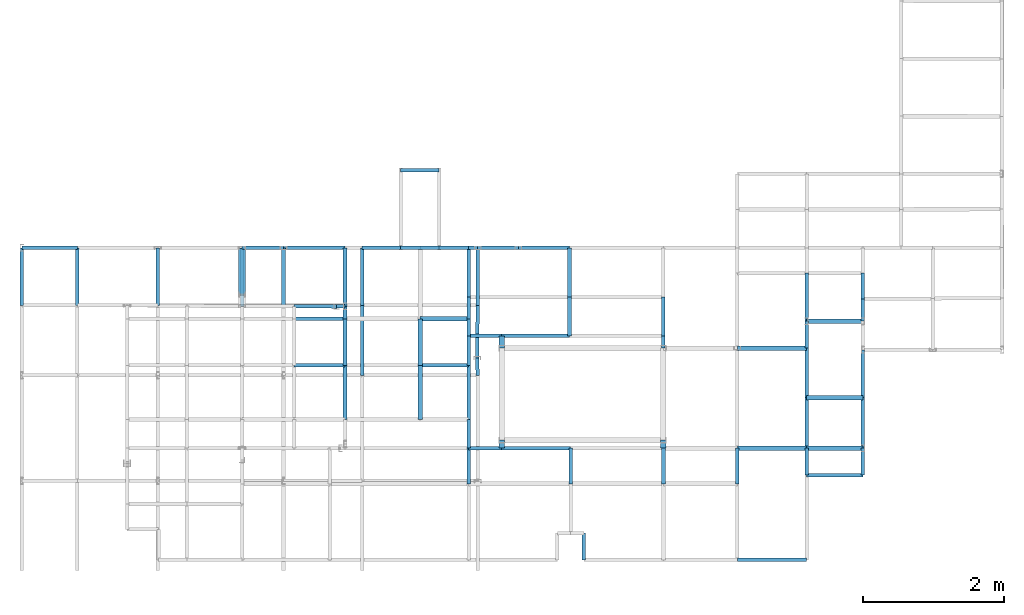
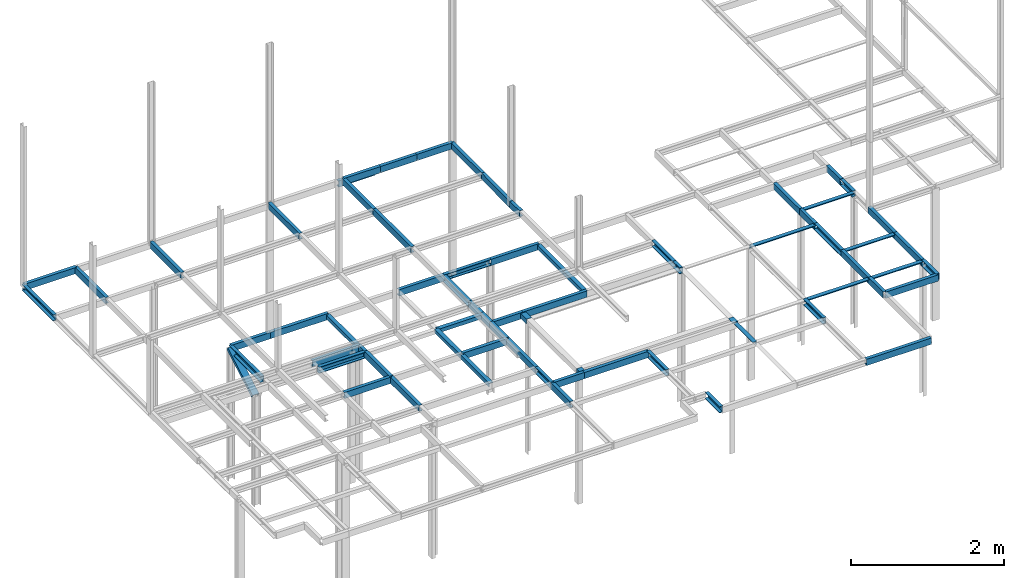
# Not in any storey, part 6 of 7: 72 beams, 1 member.
"""IFC2X3 model written with IfcOpenShell, lengths in centimetres."""

from ifc_helpers import new_model, si_unit, frame, frame_2d, origin_with_axes, origin_2d_with_axis, place, context, project, polyline, u_section, outline, extrude, material, element, save


model = new_model("IFC2X3")

# Units and contexts
model_context = context("Model", 3, precision=1e-05, world=origin_with_axes())
plan_context = context("Plan", 3, precision=1e-05, world=origin_with_axes())
ifc_project = project(units=[si_unit("LENGTHUNIT", "METRE", prefix="CENTI"), si_unit("AREAUNIT", "SQUARE_METRE", prefix="CENTI"), si_unit("VOLUMEUNIT", "CUBIC_METRE", prefix="CENTI"), si_unit("PLANEANGLEUNIT", "RADIAN"), si_unit("SOLIDANGLEUNIT", "STERADIAN"), si_unit("MASSUNIT", "GRAM"), si_unit("TIMEUNIT", "SECOND"), si_unit("THERMODYNAMICTEMPERATUREUNIT", "DEGREE_CELSIUS"), si_unit("LUMINOUSINTENSITYUNIT", "LUMEN")], contexts=[model_context, plan_context])

# Member
ifc_material = material()
member_placement = place(None, frame((-589.100036621094, 210.199996948242, 173.0), z_axis=(0.0, 0.868408043998, 0.495850248684), x_axis=(0.0, 0.495850235224, -0.868408024311)))
element("IfcMember", 1, at=member_placement, material=ifc_material, Name="UPN - de ala UPN 100", context=model_context, shape_type="SweptSolid", body=[
    extrude(u_section(Depth=10.0, FlangeWidth=5.0, WebThickness=0.6, FlangeThickness=0.85, FilletRadius=0.0, EdgeRadius=0.0, FlangeSlope=0.0, CentreOfGravityInX=0.0, at=origin_2d_with_axis()), origin_with_axes(), (0.0, 0.0, 1.0), 74.619303102534),
])

# Beams
beam_1_placement = place(None, frame((-530.299987792969, 275.0, 210.0), z_axis=(-1.0, 0.0, 0.0), x_axis=(0.0, 1.0, 0.0)))
element("IfcBeam", 2, at=beam_1_placement, material=ifc_material, Name="UPN - de ala UPN 100", context=model_context, shape_type="SweptSolid", body=[
    extrude(u_section(Depth=10.0, FlangeWidth=5.0, WebThickness=0.6, FlangeThickness=0.85, FilletRadius=0.0, EdgeRadius=0.0, FlangeSlope=0.0, CentreOfGravityInX=0.0, at=origin_2d_with_axis()), origin_with_axes(), (0.0, 0.0, 1.0), 58.800048828125),
])
beam_2_placement = place(None, frame((-589.100036621094, 192.0, 210.0), z_axis=(0.0, 1.0, 0.0), x_axis=(-1.0, 0.0, 0.0)))
element("IfcBeam", 3, at=beam_2_placement, material=ifc_material, Name="UPN - de ala UPN 100", context=model_context, shape_type="SweptSolid", body=[
    extrude(u_section(Depth=10.0, FlangeWidth=5.0, WebThickness=0.6, FlangeThickness=0.85, FilletRadius=0.0, EdgeRadius=0.0, FlangeSlope=0.0, CentreOfGravityInX=0.0, at=origin_2d_with_axis()), origin_with_axes(), (0.0, 0.0, 1.0), 83.0),
])
beam_3_placement = place(None, frame((-443.100006103516, 275.0, 210.0), z_axis=(-1.0, 0.0, 0.0), x_axis=(0.0, 1.0, 0.0)))
element("IfcBeam", 4, at=beam_3_placement, material=ifc_material, Name="UPN - de ala UPN 100", context=model_context, shape_type="SweptSolid", body=[
    extrude(u_section(Depth=10.0, FlangeWidth=5.0, WebThickness=0.6, FlangeThickness=0.85, FilletRadius=0.0, EdgeRadius=0.0, FlangeSlope=0.0, CentreOfGravityInX=0.0, at=origin_2d_with_axis()), origin_with_axes(), (0.0, 0.0, 1.0), 87.199981689453),
])
beam_4_placement = place(None, frame((-443.100006103516, 192.0, 210.0), z_axis=(0.0, 1.0, 0.0), x_axis=(-1.0, 0.0, 0.0)))
element("IfcBeam", 5, at=beam_4_placement, material=ifc_material, context=model_context, shape_type="SweptSolid", body=[
    extrude(outline(polyline([(3.0, -3.0), (3.0, 3.0), (-3.0, 3.0), (-3.0, 2.5), (2.5, 2.5), (2.5, -3.0), (3.0, -3.0)])), origin_with_axes(), (0.0, 0.0, 1.0), 83.0),
])
beam_5_placement = place(None, frame((-268.0, 275.0, 210.0), z_axis=(-1.0, 0.0, 0.0), x_axis=(0.0, 1.0, 0.0)))
element("IfcBeam", 6, at=beam_5_placement, material=ifc_material, Name="UPN - de ala UPN 100", context=model_context, shape_type="SweptSolid", body=[
    extrude(u_section(Depth=10.0, FlangeWidth=5.0, WebThickness=0.6, FlangeThickness=0.85, FilletRadius=0.0, EdgeRadius=0.0, FlangeSlope=0.0, CentreOfGravityInX=0.0, at=origin_2d_with_axis()), origin_with_axes(), (0.0, 0.0, 1.0), 68.600006103516),
])
beam_6_placement = place(None, frame((-255.0, 275.0, 210.0), z_axis=(-1.0, 0.0, 0.0), x_axis=(0.0, -1.0, 0.0)))
element("IfcBeam", 7, at=beam_6_placement, material=ifc_material, Name="UPN - de ala UPN 100", context=model_context, shape_type="SweptSolid", body=[
    extrude(u_section(Depth=10.0, FlangeWidth=5.0, WebThickness=0.6, FlangeThickness=0.85, FilletRadius=0.0, EdgeRadius=0.0, FlangeSlope=0.0, CentreOfGravityInX=0.0, at=origin_2d_with_axis()), origin_with_axes(), (0.0, 0.0, 1.0), 13.0),
])
beam_7_placement = place(None, frame((-268.0, 205.199996948242, 210.0), z_axis=(0.0, 1.0, 0.0), x_axis=(-1.0, 0.0, 0.0)))
element("IfcBeam", 8, at=beam_7_placement, material=ifc_material, Name="UPN - de ala UPN 100", context=model_context, shape_type="SweptSolid", body=[
    extrude(u_section(Depth=10.0, FlangeWidth=5.0, WebThickness=0.6, FlangeThickness=0.85, FilletRadius=0.0, EdgeRadius=0.0, FlangeSlope=0.0, CentreOfGravityInX=0.0, at=origin_2d_with_axis()), origin_with_axes(), (0.0, 0.0, 1.0), 69.800003051758),
])
beam_8_placement = place(None, frame((-197.5, 275.0, 210.0), z_axis=(-1.0, 0.0, 0.0), x_axis=(0.0, -1.0, 0.0)))
element("IfcBeam", 9, at=beam_8_placement, material=ifc_material, Name="UPN - de ala UPN 100", context=model_context, shape_type="SweptSolid", body=[
    extrude(u_section(Depth=10.0, FlangeWidth=5.0, WebThickness=0.6, FlangeThickness=0.85, FilletRadius=0.0, EdgeRadius=0.0, FlangeSlope=0.0, CentreOfGravityInX=0.0, at=origin_2d_with_axis()), origin_with_axes(), (0.0, 0.0, 1.0), 57.5),
])
beam_9_placement = place(None, frame((-124.900001525879, 275.0, 210.0), z_axis=(-1.0, 0.0, 0.0), x_axis=(0.0, 1.0, 0.0)))
element("IfcBeam", 10, at=beam_9_placement, material=ifc_material, Name="UPN - de ala UPN 100", context=model_context, shape_type="SweptSolid", body=[
    extrude(u_section(Depth=10.0, FlangeWidth=5.0, WebThickness=0.6, FlangeThickness=0.85, FilletRadius=0.0, EdgeRadius=0.0, FlangeSlope=0.0, CentreOfGravityInX=0.0, at=origin_2d_with_axis()), origin_with_axes(), (0.0, 0.0, 1.0), 72.599998474121),
])
beam_10_placement = place(None, frame((-124.900001525879, 205.199996948242, 210.0), z_axis=(0.0, 1.0, 0.0), x_axis=(-1.0, 0.0, 0.0)))
element("IfcBeam", 11, at=beam_10_placement, material=ifc_material, context=model_context, shape_type="SweptSolid", body=[
    extrude(outline(polyline([(3.0, -3.0), (3.0, 3.0), (-3.0, 3.0), (-3.0, 2.5), (2.5, 2.5), (2.5, -3.0), (3.0, -3.0)])), origin_with_axes(), (0.0, 0.0, 1.0), 69.800003051758),
])
beam_11_placement = place(None, frame((211.100006103516, 171.0, 210.0), z_axis=(0.0, 1.0, 0.0), x_axis=(1.0, 0.0, 0.0)))
element("IfcBeam", 12, at=beam_11_placement, material=ifc_material, Name="UPN - de ala UPN 100", context=model_context, shape_type="SweptSolid", body=[
    extrude(u_section(Depth=10.0, FlangeWidth=5.0, WebThickness=0.6, FlangeThickness=0.85, FilletRadius=0.0, EdgeRadius=0.0, FlangeSlope=0.0, CentreOfGravityInX=0.0, at=origin_2d_with_axis()), origin_with_axes(), (0.0, 0.0, 1.0), 68.0),
])
beam_12_placement = place(None, frame((291.100006103516, 202.699996948242, 210.0), z_axis=(0.0, 1.0, 0.0), x_axis=(1.0, 0.0, 0.0)))
element("IfcBeam", 13, at=beam_12_placement, material=ifc_material, Name="UPN - de ala UPN 100", context=model_context, shape_type="SweptSolid", body=[
    extrude(u_section(Depth=10.0, FlangeWidth=5.0, WebThickness=0.6, FlangeThickness=0.85, FilletRadius=0.0, EdgeRadius=0.0, FlangeSlope=0.0, CentreOfGravityInX=0.0, at=origin_2d_with_axis()), origin_with_axes(), (0.0, 0.0, 1.0), 36.300003051758),
])
beam_13_placement = place(None, frame((-268.0, 174.400009155273, 210.0), z_axis=(0.0, 1.0, 0.0), x_axis=(1.0, 0.0, 0.0)))
element("IfcBeam", 14, at=beam_13_placement, material=ifc_material, Name="UPN - de ala UPN 100", context=model_context, shape_type="SweptSolid", body=[
    extrude(u_section(Depth=10.0, FlangeWidth=5.0, WebThickness=0.6, FlangeThickness=0.85, FilletRadius=0.0, EdgeRadius=0.0, FlangeSlope=0.0, CentreOfGravityInX=0.0, at=origin_2d_with_axis()), origin_with_axes(), (0.0, 0.0, 1.0), 30.799987792969),
])
beam_14_placement = place(None, frame((-124.900001525879, 150.199996948242, 210.0), z_axis=(0.0, 1.0, 0.0), x_axis=(-1.0, 0.0, 0.0)))
element("IfcBeam", 15, at=beam_14_placement, material=ifc_material, context=model_context, shape_type="SweptSolid", body=[
    extrude(outline(polyline([(3.0, -3.0), (3.0, 3.0), (-3.0, 3.0), (-3.0, 2.5), (2.5, 2.5), (2.5, -3.0), (3.0, -3.0)])), origin_with_axes(), (0.0, 0.0, 1.0), 55.0),
])
beam_15_placement = place(None, frame((8.199999809265, 150.199996948242, 210.0), z_axis=(0.0, 1.0, 0.0), x_axis=(-1.0, 0.0, 0.0)))
element("IfcBeam", 16, at=beam_15_placement, material=ifc_material, Name="UPN - de ala UPN 100", context=model_context, shape_type="SweptSolid", body=[
    extrude(u_section(Depth=10.0, FlangeWidth=5.0, WebThickness=0.6, FlangeThickness=0.85, FilletRadius=0.0, EdgeRadius=0.0, FlangeSlope=0.0, CentreOfGravityInX=0.0, at=origin_2d_with_axis()), origin_with_axes(), (0.0, 0.0, 1.0), 55.0),
])
beam_16_placement = place(None, frame((291.100006103516, 171.0, 210.0), z_axis=(0.0, 1.0, 0.0), x_axis=(-1.0, 0.0, 0.0)))
element("IfcBeam", 17, at=beam_16_placement, material=ifc_material, Name="UPN - de ala UPN 100", context=model_context, shape_type="SweptSolid", body=[
    extrude(u_section(Depth=10.0, FlangeWidth=5.0, WebThickness=0.6, FlangeThickness=0.85, FilletRadius=0.0, EdgeRadius=0.0, FlangeSlope=0.0, CentreOfGravityInX=0.0, at=origin_2d_with_axis()), origin_with_axes(), (0.0, 0.0, 1.0), 31.699996948242),
])
beam_17_placement = place(None, frame((-455.200012207031, 191.800003051758, 210.0), z_axis=(0.999863429598, 0.016526407745, 0.0), x_axis=(-0.016526408494, 0.999863445759, 0.0)))
element("IfcBeam", 18, at=beam_17_placement, material=ifc_material, Name="UPN - de ala UPN 100", context=model_context, shape_type="SweptSolid", body=[
    extrude(u_section(Depth=10.0, FlangeWidth=5.0, WebThickness=0.6, FlangeThickness=0.85, FilletRadius=0.0, EdgeRadius=0.0, FlangeSlope=0.0, CentreOfGravityInX=0.0, at=frame_2d((-5.83e-09, 0.0), x_axis=(1.0, 0.0))), origin_with_axes(), (0.0, 0.0, 1.0), 12.10165883193),
])
beam_18_placement = place(None, frame((-443.100006103516, 174.400009155273, 210.0), z_axis=(0.0, 1.0, 0.0), x_axis=(1.0, 0.0, 0.0)))
element("IfcBeam", 19, at=beam_18_placement, material=ifc_material, Name="UPN - de ala UPN 100", context=model_context, shape_type="SweptSolid", body=[
    extrude(u_section(Depth=10.0, FlangeWidth=5.0, WebThickness=0.6, FlangeThickness=0.85, FilletRadius=0.0, EdgeRadius=0.0, FlangeSlope=0.0, CentreOfGravityInX=0.0, at=origin_2d_with_axis()), origin_with_axes(), (0.0, 0.0, 1.0), 17.599990844727),
])
beam_19_placement = place(None, frame((-455.200012207031, 191.800003051758, 210.0), z_axis=(-0.999998610944, 0.001666766077, 0.0), x_axis=(0.001666766126, 0.999998629093, 0.0)))
element("IfcBeam", 20, at=beam_19_placement, material=ifc_material, Name="UPN - de ala UPN 100", context=model_context, shape_type="SweptSolid", body=[
    extrude(u_section(Depth=10.0, FlangeWidth=5.0, WebThickness=0.6, FlangeThickness=0.85, FilletRadius=0.0, EdgeRadius=0.0, FlangeSlope=0.0, CentreOfGravityInX=0.0, at=frame_2d((-1.126e-09, 0.0), x_axis=(1.0, 0.0))), origin_with_axes(), (0.0, 0.0, 1.0), 60.000083343448),
])
beam_20_placement = place(None, frame((-443.100006103516, 174.400009155273, 210.0), z_axis=(-1.0, 0.0, 0.0), x_axis=(0.0, -1.0, 0.0)))
element("IfcBeam", 21, at=beam_20_placement, material=ifc_material, Name="UPN - de ala UPN 100", context=model_context, shape_type="SweptSolid", body=[
    extrude(u_section(Depth=10.0, FlangeWidth=5.0, WebThickness=0.6, FlangeThickness=0.85, FilletRadius=0.0, EdgeRadius=0.0, FlangeSlope=0.0, CentreOfGravityInX=0.0, at=origin_2d_with_axis()), origin_with_axes(), (0.0, 0.0, 1.0), 72.100006103516),
])
beam_21_placement = place(None, frame((-443.100006103516, 108.200004577637, 210.0), z_axis=(0.0, 1.0, 0.0), x_axis=(1.0, 0.0, 0.0)))
element("IfcBeam", 22, at=beam_21_placement, material=ifc_material, Name="UPN - de ala UPN 100", context=model_context, shape_type="SweptSolid", body=[
    extrude(u_section(Depth=10.0, FlangeWidth=5.0, WebThickness=0.6, FlangeThickness=0.85, FilletRadius=0.0, EdgeRadius=0.0, FlangeSlope=0.0, CentreOfGravityInX=0.0, at=origin_2d_with_axis()), origin_with_axes(), (0.0, 0.0, 1.0), 66.200004577637),
])
beam_22_placement = place(None, frame((-268.0, 174.400009155273, 210.0), z_axis=(-1.0, 0.0, 0.0), x_axis=(0.0, -1.0, 0.0)))
element("IfcBeam", 23, at=beam_22_placement, material=ifc_material, context=model_context, shape_type="SweptSolid", body=[
    extrude(outline(polyline([(3.0, -3.0), (3.0, 3.0), (-3.0, 3.0), (-3.0, 2.5), (2.5, 2.5), (2.5, -3.0), (3.0, -3.0)])), origin_with_axes(), (0.0, 0.0, 1.0), 68.600006103516),
])
beam_23_placement = place(None, frame((-336.600006103516, 108.200004577637, 210.0), z_axis=(0.0, 1.0, 0.0), x_axis=(-1.0, 0.0, 0.0)))
element("IfcBeam", 24, at=beam_23_placement, material=ifc_material, context=model_context, shape_type="SweptSolid", body=[
    extrude(outline(polyline([(3.0, -3.0), (3.0, 3.0), (-3.0, 3.0), (-3.0, 2.5), (2.5, 2.5), (2.5, -3.0), (3.0, -3.0)])), origin_with_axes(), (0.0, 0.0, 1.0), 66.200004577637),
])
beam_24_placement = place(None, frame((-268.0, 150.199996948242, 210.0), z_axis=(0.0, 1.0, 0.0), x_axis=(1.0, 0.0, 0.0)))
element("IfcBeam", 25, at=beam_24_placement, material=ifc_material, Name="UPN - de ala UPN 100", context=model_context, shape_type="SweptSolid", body=[
    extrude(u_section(Depth=10.0, FlangeWidth=5.0, WebThickness=0.6, FlangeThickness=0.85, FilletRadius=0.0, EdgeRadius=0.0, FlangeSlope=0.0, CentreOfGravityInX=0.0, at=origin_2d_with_axis()), origin_with_axes(), (0.0, 0.0, 1.0), 24.200012207031),
])
beam_25_placement = place(None, frame((291.100006103516, 171.0, 210.0), z_axis=(-1.0, 0.0, 0.0), x_axis=(0.0, 0.0, 1.0)))
element("IfcBeam", 26, at=beam_25_placement, material=ifc_material, context=model_context, shape_type="SweptSolid", body=[
    extrude(outline(polyline([(3.0, -3.0), (3.0, 3.0), (-3.0, 3.0), (-3.0, 2.5), (2.5, 2.5), (2.5, -3.0), (3.0, -3.0)])), origin_with_axes(), (0.0, 0.0, 1.0), 80.0),
])
beam_26_placement = place(None, frame((211.100006103516, 132.699996948242, 210.0), z_axis=(0.0, 1.0, 0.0), x_axis=(1.0, 0.0, 0.0)))
element("IfcBeam", 27, at=beam_26_placement, material=ifc_material, Name="UPN - de ala UPN 100", context=model_context, shape_type="SweptSolid", body=[
    extrude(u_section(Depth=10.0, FlangeWidth=5.0, WebThickness=0.6, FlangeThickness=0.85, FilletRadius=0.0, EdgeRadius=0.0, FlangeSlope=0.0, CentreOfGravityInX=0.0, at=origin_2d_with_axis()), origin_with_axes(), (0.0, 0.0, 1.0), 38.300003051758),
])
beam_27_placement = place(None, frame((-221.0, 150.199996948242, 210.0), z_axis=(-1.0, 0.0, 0.0), x_axis=(0.0, 1.0, 0.0)))
element("IfcBeam", 28, at=beam_27_placement, material=ifc_material, Name="UPN - de ala UPN 100", context=model_context, shape_type="SweptSolid", body=[
    extrude(u_section(Depth=10.0, FlangeWidth=5.0, WebThickness=0.6, FlangeThickness=0.85, FilletRadius=0.0, EdgeRadius=0.0, FlangeSlope=0.0, CentreOfGravityInX=0.0, at=origin_2d_with_axis()), origin_with_axes(), (0.0, 0.0, 1.0), 47.0),
])
beam_28_placement = place(None, frame((-268.0, 108.200004577637, 210.0), z_axis=(0.0, 1.0, 0.0), x_axis=(1.0, 0.0, 0.0)))
element("IfcBeam", 29, at=beam_28_placement, material=ifc_material, Name="UPN - de ala UPN 100", context=model_context, shape_type="SweptSolid", body=[
    extrude(u_section(Depth=10.0, FlangeWidth=5.0, WebThickness=0.6, FlangeThickness=0.85, FilletRadius=0.0, EdgeRadius=0.0, FlangeSlope=0.0, CentreOfGravityInX=0.0, at=origin_2d_with_axis()), origin_with_axes(), (0.0, 0.0, 1.0), 41.999992370605),
])
beam_29_placement = place(None, frame((-124.900001525879, 150.199996948242, 210.0), z_axis=(-1.0, 0.0, 0.0), x_axis=(0.0, 1.0, 0.0)))
element("IfcBeam", 30, at=beam_29_placement, material=ifc_material, Name="UPN - de ala UPN 100", context=model_context, shape_type="SweptSolid", body=[
    extrude(u_section(Depth=10.0, FlangeWidth=5.0, WebThickness=0.6, FlangeThickness=0.85, FilletRadius=0.0, EdgeRadius=0.0, FlangeSlope=0.0, CentreOfGravityInX=0.0, at=origin_2d_with_axis()), origin_with_axes(), (0.0, 0.0, 1.0), 96.099998474121),
])
beam_30_placement = place(None, frame((-221.0, 132.699996948242, 210.0), z_axis=(0.0, 1.0, 0.0), x_axis=(-1.0, 0.0, 0.0)))
element("IfcBeam", 31, at=beam_30_placement, material=ifc_material, context=model_context, shape_type="SweptSolid", body=[
    extrude(outline(polyline([(4.0, -4.0), (4.0, 4.0), (-4.0, 4.0), (-4.0, 3.199996948242), (3.199996948242, 3.199996948242), (3.199996948242, -4.0), (4.0, -4.0)])), origin_with_axes(), (0.0, 0.0, 1.0), 17.5),
])
beam_31_placement = place(None, frame((8.199999809265, 132.699996948242, 210.0), z_axis=(0.0, 1.0, 0.0), x_axis=(-1.0, 0.0, 0.0)))
element("IfcBeam", 32, at=beam_31_placement, material=ifc_material, Name="UPN - de ala UPN 100", context=model_context, shape_type="SweptSolid", body=[
    extrude(u_section(Depth=10.0, FlangeWidth=5.0, WebThickness=0.6, FlangeThickness=0.85, FilletRadius=0.0, EdgeRadius=0.0, FlangeSlope=0.0, CentreOfGravityInX=0.0, at=origin_2d_with_axis()), origin_with_axes(), (0.0, 0.0, 1.0), 17.5),
])
beam_32_placement = place(None, frame((211.100006103516, 132.699996948242, 210.0), z_axis=(-1.0, 0.0, 0.0), x_axis=(0.0, 0.0, 1.0)))
element("IfcBeam", 33, at=beam_32_placement, material=ifc_material, context=model_context, shape_type="SweptSolid", body=[
    extrude(outline(polyline([(3.0, -3.0), (3.0, 3.0), (-3.0, 3.0), (-3.0, 2.5), (2.5, 2.5), (2.5, -3.0), (3.0, -3.0)])), origin_with_axes(), (0.0, 0.0, 1.0), 98.000007629395),
])
beam_33_placement = place(None, frame((211.100006103516, 62.600006103516, 210.0), z_axis=(0.0, 1.0, 0.0), x_axis=(-1.0, 0.0, 0.0)))
element("IfcBeam", 34, at=beam_33_placement, material=ifc_material, Name="UPN - de ala UPN 100", context=model_context, shape_type="SweptSolid", body=[
    extrude(u_section(Depth=10.0, FlangeWidth=5.0, WebThickness=0.6, FlangeThickness=0.85, FilletRadius=0.0, EdgeRadius=0.0, FlangeSlope=0.0, CentreOfGravityInX=0.0, at=origin_2d_with_axis()), origin_with_axes(), (0.0, 0.0, 1.0), 70.099990844727),
])
beam_34_placement = place(None, frame((291.100006103516, 62.600006103516, 210.0), z_axis=(0.0, 1.0, 0.0), x_axis=(1.0, 0.0, 0.0)))
element("IfcBeam", 35, at=beam_34_placement, material=ifc_material, Name="UPN - de ala UPN 100", context=model_context, shape_type="SweptSolid", body=[
    extrude(u_section(Depth=10.0, FlangeWidth=5.0, WebThickness=0.6, FlangeThickness=0.85, FilletRadius=0.0, EdgeRadius=0.0, FlangeSlope=0.0, CentreOfGravityInX=0.0, at=origin_2d_with_axis()), origin_with_axes(), (0.0, 0.0, 1.0), 67.800003051758),
])
beam_35_placement = place(None, frame((-443.100006103516, 108.200004577637, 210.0), z_axis=(-1.0, 0.0, 0.0), x_axis=(0.0, 1.0, 0.0)))
element("IfcBeam", 36, at=beam_35_placement, material=ifc_material, Name="UPN - de ala UPN 100", context=model_context, shape_type="SweptSolid", body=[
    extrude(u_section(Depth=10.0, FlangeWidth=5.0, WebThickness=0.6, FlangeThickness=0.85, FilletRadius=0.0, EdgeRadius=0.0, FlangeSlope=0.0, CentreOfGravityInX=0.0, at=origin_2d_with_axis()), origin_with_axes(), (0.0, 0.0, 1.0), 72.100006103516),
])
beam_36_placement = place(None, frame((-443.100006103516, 31.599998474121, 210.0), z_axis=(0.0, 1.0, 0.0), x_axis=(1.0, 0.0, 0.0)))
element("IfcBeam", 37, at=beam_36_placement, material=ifc_material, Name="UPN - de ala UPN 100", context=model_context, shape_type="SweptSolid", body=[
    extrude(u_section(Depth=10.0, FlangeWidth=5.0, WebThickness=0.6, FlangeThickness=0.85, FilletRadius=0.0, EdgeRadius=0.0, FlangeSlope=0.0, CentreOfGravityInX=0.0, at=origin_2d_with_axis()), origin_with_axes(), (0.0, 0.0, 1.0), 76.600006103516),
])
beam_37_placement = place(None, frame((-268.0, 108.200004577637, 210.0), z_axis=(-1.0, 0.0, 0.0), x_axis=(0.0, 1.0, 0.0)))
element("IfcBeam", 38, at=beam_37_placement, material=ifc_material, Name="UPN - de ala UPN 100", context=model_context, shape_type="SweptSolid", body=[
    extrude(u_section(Depth=10.0, FlangeWidth=5.0, WebThickness=0.6, FlangeThickness=0.85, FilletRadius=0.0, EdgeRadius=0.0, FlangeSlope=0.0, CentreOfGravityInX=0.0, at=origin_2d_with_axis()), origin_with_axes(), (0.0, 0.0, 1.0), 68.600006103516),
])
beam_38_placement = place(None, frame((-336.600006103516, 31.599998474121, 210.0), z_axis=(0.0, 1.0, 0.0), x_axis=(-1.0, 0.0, 0.0)))
element("IfcBeam", 39, at=beam_38_placement, material=ifc_material, context=model_context, shape_type="SweptSolid", body=[
    extrude(outline(polyline([(3.0, -3.0), (3.0, 3.0), (-3.0, 3.0), (-3.0, 2.5), (2.5, 2.5), (2.5, -3.0), (3.0, -3.0)])), origin_with_axes(), (0.0, 0.0, 1.0), 76.600006103516),
])
beam_39_placement = place(None, frame((-268.0, 31.599998474121, 210.0), z_axis=(0.0, 1.0, 0.0), x_axis=(1.0, 0.0, 0.0)))
element("IfcBeam", 40, at=beam_39_placement, material=ifc_material, Name="UPN - de ala UPN 100", context=model_context, shape_type="SweptSolid", body=[
    extrude(u_section(Depth=10.0, FlangeWidth=5.0, WebThickness=0.6, FlangeThickness=0.85, FilletRadius=0.0, EdgeRadius=0.0, FlangeSlope=0.0, CentreOfGravityInX=0.0, at=origin_2d_with_axis()), origin_with_axes(), (0.0, 0.0, 1.0), 76.600006103516),
])
beam_40_placement = place(None, frame((291.100006103516, 62.600002288818, 210.0), z_axis=(-1.0, 0.0, 0.0), x_axis=(0.0, 0.0, 1.0)))
element("IfcBeam", 41, at=beam_40_placement, material=ifc_material, context=model_context, shape_type="SweptSolid", body=[
    extrude(outline(polyline([(3.0, -3.0), (3.0, 2.999996185303), (-3.0, 3.000003814697), (-3.0, 2.500003814697), (2.5, 2.499996185303), (2.5, -3.0), (3.0, -3.0)])), origin_with_axes(), (0.0, 0.0, 1.0), 80.0),
])
for number, where, z_axis, x_axis, name in (
    (42, (211.100006103516, -9.000003814697, 210.0), (0.0, 1.0, 0.0), (1.0, 0.0, 0.0), "UPN - de ala UPN 100"),
    (43, (291.100006103516, -9.000003814697, 210.0), (0.0, 1.0, 0.0), (1.0, 0.0, 0.0), "UPN - de ala UPN 100"),
):
    element("IfcBeam", number, at=place(None, frame(where, z_axis=z_axis, x_axis=x_axis)), material=ifc_material, Name=name, context=model_context, shape_type="SweptSolid", body=[
        extrude(u_section(Depth=10.0, FlangeWidth=5.0, WebThickness=0.6, FlangeThickness=0.85, FilletRadius=0.0, EdgeRadius=0.0, FlangeSlope=0.0, CentreOfGravityInX=0.0, at=origin_2d_with_axis()), origin_with_axes(), (0.0, 0.0, 1.0), 71.600006103516),
    ])
beam_41_placement = place(None, frame((-268.0, -8.999998092651, 210.0), z_axis=(0.0, 1.0, 0.0), x_axis=(-1.0, 0.0, 0.0)))
element("IfcBeam", 44, at=beam_41_placement, material=ifc_material, Name="UPN - de ala UPN 100", context=model_context, shape_type="SweptSolid", body=[
    extrude(u_section(Depth=10.0, FlangeWidth=5.0, WebThickness=0.6, FlangeThickness=0.85, FilletRadius=0.0, EdgeRadius=0.0, FlangeSlope=0.0, CentreOfGravityInX=0.0, at=origin_2d_with_axis()), origin_with_axes(), (0.0, 0.0, 1.0), 40.599998474121),
])
beam_42_placement = place(None, frame((-221.0, -9.000000238419, 210.0), z_axis=(0.0, 1.0, 0.0), x_axis=(-1.0, 0.0, 0.0)))
element("IfcBeam", 45, at=beam_42_placement, material=ifc_material, context=model_context, shape_type="SweptSolid", body=[
    extrude(outline(polyline([(4.0, -4.0), (4.0, 4.0), (-4.0, 4.0), (-4.0, 3.199996948242), (3.199996948242, 3.199996948242), (3.199996948242, -4.0), (4.0, -4.0)])), origin_with_axes(), (0.0, 0.0, 1.0), 11.300000190735),
])
beam_43_placement = place(None, frame((8.199999809265, -9.000000238419, 210.0), z_axis=(0.0, 1.0, 0.0), x_axis=(0.0, 0.0, 1.0)))
element("IfcBeam", 46, at=beam_43_placement, material=ifc_material, context=model_context, shape_type="SweptSolid", body=[
    extrude(outline(polyline([(4.0, -4.0), (4.0, 4.0), (-4.0, 4.0), (-4.0, 3.199999809265), (3.199996948242, 3.199999809265), (3.199996948242, -4.0), (4.0, -4.0)])), origin_with_axes(), (0.0, 0.0, 1.0), 11.300000190735),
])
beam_44_placement = place(None, frame((-221.0, -9.0, 210.0), z_axis=(-1.0, 0.0, 0.0), x_axis=(0.0, 1.0, 0.0)))
element("IfcBeam", 47, at=beam_44_placement, material=ifc_material, Name="UPN - de ala UPN 100", context=model_context, shape_type="SweptSolid", body=[
    extrude(u_section(Depth=10.0, FlangeWidth=5.0, WebThickness=0.6, FlangeThickness=0.85, FilletRadius=0.0, EdgeRadius=0.0, FlangeSlope=0.0, CentreOfGravityInX=0.0, at=frame_2d((2.38419e-07, 0.0), x_axis=(1.0, 0.0))), origin_with_axes(), (0.0, 0.0, 1.0), 47.0),
])
beam_45_placement = place(None, frame((-268.0, -59.600002288818, 210.0), z_axis=(0.0, 1.0, 0.0), x_axis=(1.0, 0.0, 0.0)))
element("IfcBeam", 48, at=beam_45_placement, material=ifc_material, Name="UPN - de ala UPN 100", context=model_context, shape_type="SweptSolid", body=[
    extrude(u_section(Depth=10.0, FlangeWidth=5.0, WebThickness=0.6, FlangeThickness=0.85, FilletRadius=0.0, EdgeRadius=0.0, FlangeSlope=0.0, CentreOfGravityInX=0.0, at=origin_2d_with_axis()), origin_with_axes(), (0.0, 0.0, 1.0), 50.600002288818),
])
beam_46_placement = place(None, frame((-123.300003051758, -9.0, 210.0), z_axis=(-1.0, 0.0, 0.0), x_axis=(0.0, 1.0, 0.0)))
element("IfcBeam", 49, at=beam_46_placement, material=ifc_material, Name="UPN - de ala UPN 100", context=model_context, shape_type="SweptSolid", body=[
    extrude(u_section(Depth=10.0, FlangeWidth=5.0, WebThickness=0.6, FlangeThickness=0.85, FilletRadius=0.0, EdgeRadius=0.0, FlangeSlope=0.0, CentreOfGravityInX=0.0, at=frame_2d((2.38419e-07, 0.0), x_axis=(1.0, 0.0))), origin_with_axes(), (0.0, 0.0, 1.0), 97.699996948242),
])
beam_47_placement = place(None, frame((-123.300003051758, -59.600002288818, 210.0), z_axis=(0.0, 1.0, 0.0), x_axis=(-1.0, 0.0, 0.0)))
element("IfcBeam", 50, at=beam_47_placement, material=ifc_material, Name="UPN - de ala UPN 100", context=model_context, shape_type="SweptSolid", body=[
    extrude(u_section(Depth=10.0, FlangeWidth=5.0, WebThickness=0.6, FlangeThickness=0.85, FilletRadius=0.0, EdgeRadius=0.0, FlangeSlope=0.0, CentreOfGravityInX=0.0, at=origin_2d_with_axis()), origin_with_axes(), (0.0, 0.0, 1.0), 50.600002288818),
])
beam_48_placement = place(None, frame((8.199999809265, -59.600002288818, 210.0), z_axis=(0.0, 1.0, 0.0), x_axis=(-1.0, 0.0, 0.0)))
element("IfcBeam", 51, at=beam_48_placement, material=ifc_material, context=model_context, shape_type="SweptSolid", body=[
    extrude(outline(polyline([(-3.0, -3.0), (-2.5, -3.0), (-2.5, 2.5), (3.0, 2.5), (3.0, 3.0), (-3.0, 3.0), (-3.0, -3.0)])), origin_with_axes(), (0.0, 0.0, 1.0), 50.600002288818),
])
beam_49_placement = place(None, frame((211.100006103516, -9.0, 210.0), z_axis=(-1.0, 0.0, 0.0), x_axis=(0.0, 0.0, 1.0)))
element("IfcBeam", 52, at=beam_49_placement, material=ifc_material, context=model_context, shape_type="SweptSolid", body=[
    extrude(outline(polyline([(3.0, -3.0), (3.0, 3.0), (-3.0, 3.0), (-3.0, 2.5), (2.5, 2.5), (2.5, -3.0), (3.0, -3.0)])), origin_with_axes(), (0.0, 0.0, 1.0), 98.000007629395),
])
beam_50_placement = place(None, frame((113.099998474121, -59.600002288818, 210.0), z_axis=(0.0, 1.0, 0.0), x_axis=(-1.0, 0.0, 0.0)))
element("IfcBeam", 53, at=beam_50_placement, material=ifc_material, Name="UPN - de ala UPN 100", context=model_context, shape_type="SweptSolid", body=[
    extrude(u_section(Depth=10.0, FlangeWidth=5.0, WebThickness=0.6, FlangeThickness=0.85, FilletRadius=0.0, EdgeRadius=0.0, FlangeSlope=0.0, CentreOfGravityInX=0.0, at=origin_2d_with_axis()), origin_with_axes(), (0.0, 0.0, 1.0), 50.600002288818),
])
beam_51_placement = place(None, frame((291.100006103516, -9.0, 210.0), z_axis=(-1.0, 0.0, 0.0), x_axis=(0.0, 0.0, 1.0)))
element("IfcBeam", 54, at=beam_51_placement, material=ifc_material, context=model_context, shape_type="SweptSolid", body=[
    extrude(outline(polyline([(3.0, -3.0), (3.0, 2.999999523163), (-3.0, 3.000000476837), (-3.0, 2.500000476837), (2.5, 2.5), (2.5, -3.0), (3.0, -3.0)])), origin_with_axes(), (0.0, 0.0, 1.0), 80.0),
])
for number, where, z_axis, x_axis, name in (
    (55, (211.100006103516, -47.400001525879, 210.0), (0.0, 1.0, 0.0), (1.0, 0.0, 0.0), "UPN - de ala UPN 100"),
    (56, (291.100006103516, -47.400001525879, 210.0), (0.0, 1.0, 0.0), (-1.0, 0.0, 0.0), "UPN - de ala UPN 100"),
):
    element("IfcBeam", number, at=place(None, frame(where, z_axis=z_axis, x_axis=x_axis)), material=ifc_material, Name=name, context=model_context, shape_type="SweptSolid", body=[
        extrude(u_section(Depth=10.0, FlangeWidth=5.0, WebThickness=0.6, FlangeThickness=0.85, FilletRadius=0.0, EdgeRadius=0.0, FlangeSlope=0.0, CentreOfGravityInX=0.0, at=origin_2d_with_axis()), origin_with_axes(), (0.0, 0.0, 1.0), 38.400001525879),
    ])
beam_52_placement = place(None, frame((291.100006103516, -47.400001525879, 210.0), z_axis=(-1.0, 0.0, 0.0), x_axis=(0.0, 1.0, 0.0)))
element("IfcBeam", 57, at=beam_52_placement, material=ifc_material, Name="UPN - de ala UPN 100", context=model_context, shape_type="SweptSolid", body=[
    extrude(u_section(Depth=10.0, FlangeWidth=5.0, WebThickness=0.6, FlangeThickness=0.85, FilletRadius=0.0, EdgeRadius=0.0, FlangeSlope=0.0, CentreOfGravityInX=0.0, at=origin_2d_with_axis()), origin_with_axes(), (0.0, 0.0, 1.0), 80.0),
])
beam_53_placement = place(None, frame((-104.599998474121, -167.5, 210.0), z_axis=(0.0, 1.0, 0.0), x_axis=(-1.0, 0.0, 0.0)))
element("IfcBeam", 58, at=beam_53_placement, material=ifc_material, Name="UPN - de ala UPN 100", context=model_context, shape_type="SweptSolid", body=[
    extrude(u_section(Depth=10.0, FlangeWidth=5.0, WebThickness=0.6, FlangeThickness=0.85, FilletRadius=0.0, EdgeRadius=0.0, FlangeSlope=0.0, CentreOfGravityInX=0.0, at=origin_2d_with_axis()), origin_with_axes(), (0.0, 0.0, 1.0), 38.199996948242),
])
beam_54_placement = place(None, frame((211.100006103516, -167.5, 210.0), z_axis=(-1.0, 0.0, 0.0), x_axis=(0.0, 1.0, 0.0)))
element("IfcBeam", 59, at=beam_54_placement, material=ifc_material, Name="UPN - de ala UPN 100", context=model_context, shape_type="SweptSolid", body=[
    extrude(u_section(Depth=10.0, FlangeWidth=5.0, WebThickness=0.6, FlangeThickness=0.85, FilletRadius=0.0, EdgeRadius=0.0, FlangeSlope=0.0, CentreOfGravityInX=0.0, at=origin_2d_with_axis()), origin_with_axes(), (0.0, 0.0, 1.0), 98.000007629395),
])
beam_55_placement = place(None, frame((-309.600006103516, 385.0, 326.5), z_axis=(-1.0, 0.0, 0.0), x_axis=(0.0, 1.0, 0.0)))
element("IfcBeam", 60, at=beam_55_placement, material=ifc_material, Name="UPN - de ala UPN 100", context=model_context, shape_type="SweptSolid", body=[
    extrude(u_section(Depth=10.0, FlangeWidth=5.0, WebThickness=0.6, FlangeThickness=0.85, FilletRadius=0.0, EdgeRadius=0.0, FlangeSlope=0.0, CentreOfGravityInX=0.0, at=origin_2d_with_axis()), origin_with_axes(), (0.0, 0.0, 1.0), 54.600006103516),
])
beam_56_placement = place(None, frame((-822.400024414062, 275.0, 416.5), z_axis=(-1.0, 0.0, 0.0), x_axis=(0.0, 1.0, 0.0)))
element("IfcBeam", 61, at=beam_56_placement, material=ifc_material, Name="UPN - de ala UPN 100", context=model_context, shape_type="SweptSolid", body=[
    extrude(u_section(Depth=10.0, FlangeWidth=5.0, WebThickness=0.6, FlangeThickness=0.85, FilletRadius=0.0, EdgeRadius=0.0, FlangeSlope=0.0, CentreOfGravityInX=0.0, at=origin_2d_with_axis()), origin_with_axes(), (0.0, 0.0, 1.0), 78.899963378906),
])
for number, where, z_axis, x_axis, name in (
    (62, (-901.299987792969, 193.5, 416.5), (0.0, 1.0, 0.0), (-1.0, 0.0, 0.0), "UPN - de ala UPN 100"),
    (63, (-822.400024414062, 193.5, 416.5), (0.0, 1.0, 0.0), (1.0, 0.0, 0.0), "UPN - de ala UPN 100"),
    (64, (-708.5, 193.5, 416.5), (0.0, 1.0, 0.0), (1.0, 0.0, 0.0), "UPN - de ala UPN 100"),
    (65, (-530.299987792969, 193.5, 416.5), (0.0, 1.0, 0.0), (1.0, 0.0, 0.0), "UPN - de ala UPN 100"),
):
    element("IfcBeam", number, at=place(None, frame(where, z_axis=z_axis, x_axis=x_axis)), material=ifc_material, Name=name, context=model_context, shape_type="SweptSolid", body=[
        extrude(u_section(Depth=10.0, FlangeWidth=5.0, WebThickness=0.6, FlangeThickness=0.85, FilletRadius=0.0, EdgeRadius=0.0, FlangeSlope=0.0, CentreOfGravityInX=0.0, at=origin_2d_with_axis()), origin_with_axes(), (0.0, 0.0, 1.0), 81.5),
    ])
beam_57_placement = place(None, frame((-364.200012207031, 275.0, 416.5), z_axis=(-1.0, 0.0, 0.0), x_axis=(0.0, 1.0, 0.0)))
element("IfcBeam", 66, at=beam_57_placement, material=ifc_material, Name="UPN - de ala UPN 100", context=model_context, shape_type="SweptSolid", body=[
    extrude(u_section(Depth=10.0, FlangeWidth=5.0, WebThickness=0.6, FlangeThickness=0.85, FilletRadius=0.0, EdgeRadius=0.0, FlangeSlope=0.0, CentreOfGravityInX=0.0, at=origin_2d_with_axis()), origin_with_axes(), (0.0, 0.0, 1.0), 54.600006103516),
])
beam_58_placement = place(None, frame((-418.800018310547, 193.5, 416.5), z_axis=(0.0, 1.0, 0.0), x_axis=(1.0, 0.0, 0.0)))
element("IfcBeam", 67, at=beam_58_placement, material=ifc_material, Name="UPN - de ala UPN 100", context=model_context, shape_type="SweptSolid", body=[
    extrude(u_section(Depth=10.0, FlangeWidth=5.0, WebThickness=0.6, FlangeThickness=0.85, FilletRadius=0.0, EdgeRadius=0.0, FlangeSlope=0.0, CentreOfGravityInX=0.0, at=origin_2d_with_axis()), origin_with_axes(), (0.0, 0.0, 1.0), 81.5),
])
for number, where, z_axis, x_axis, name in (
    (68, (-309.600006103516, 275.0, 416.5), (-1.0, 0.0, 0.0), (0.0, 1.0, 0.0), "UPN - de ala UPN 100"),
    (69, (-255.0, 275.0, 416.5), (-1.0, 0.0, 0.0), (0.0, 1.0, 0.0), "UPN - de ala UPN 100"),
):
    element("IfcBeam", number, at=place(None, frame(where, z_axis=z_axis, x_axis=x_axis)), material=ifc_material, Name=name, context=model_context, shape_type="SweptSolid", body=[
        extrude(u_section(Depth=10.0, FlangeWidth=5.0, WebThickness=0.6, FlangeThickness=0.85, FilletRadius=0.0, EdgeRadius=0.0, FlangeSlope=0.0, CentreOfGravityInX=0.0, at=origin_2d_with_axis()), origin_with_axes(), (0.0, 0.0, 1.0), 54.600006103516),
    ])
beam_59_placement = place(None, frame((-255.0, 193.5, 416.5), z_axis=(0.0, 1.0, 0.0), x_axis=(1.0, 0.0, 0.0)))
element("IfcBeam", 70, at=beam_59_placement, material=ifc_material, Name="UPN - de ala UPN 100", context=model_context, shape_type="SweptSolid", body=[
    extrude(u_section(Depth=10.0, FlangeWidth=5.0, WebThickness=0.6, FlangeThickness=0.85, FilletRadius=0.0, EdgeRadius=0.0, FlangeSlope=0.0, CentreOfGravityInX=0.0, at=origin_2d_with_axis()), origin_with_axes(), (0.0, 0.0, 1.0), 81.5),
])
beam_60_placement = place(None, frame((-418.800018310547, 94.200004577637, 416.5), z_axis=(0.0, 1.0, 0.0), x_axis=(1.0, 0.0, 0.0)))
element("IfcBeam", 71, at=beam_60_placement, material=ifc_material, Name="UPN - de ala UPN 100", context=model_context, shape_type="SweptSolid", body=[
    extrude(u_section(Depth=10.0, FlangeWidth=5.0, WebThickness=0.6, FlangeThickness=0.85, FilletRadius=0.0, EdgeRadius=0.0, FlangeSlope=0.0, CentreOfGravityInX=0.0, at=origin_2d_with_axis()), origin_with_axes(), (0.0, 0.0, 1.0), 99.299995422363),
])
beam_61_placement = place(None, frame((-255.900009155273, 119.0, 416.5), z_axis=(0.012079778359, 0.999927036816, 0.0), x_axis=(0.999927043915, -0.012079778127, 0.0)))
element("IfcBeam", 72, at=beam_61_placement, material=ifc_material, Name="UPN - de ala UPN 100", context=model_context, shape_type="SweptSolid", body=[
    extrude(u_section(Depth=10.0, FlangeWidth=5.0, WebThickness=0.6, FlangeThickness=0.85, FilletRadius=0.0, EdgeRadius=0.0, FlangeSlope=0.0, CentreOfGravityInX=0.0, at=frame_2d((2.364e-08, 0.0), x_axis=(1.0, 0.0))), origin_with_axes(), (0.0, 0.0, 1.0), 74.505436153878),
])
beam_62_placement = place(None, frame((-255.0, 94.200004577637, 416.5), z_axis=(-0.036266824329, 0.999342142338, 0.0), x_axis=(0.999342143536, 0.036266826093, 0.0)))
element("IfcBeam", 73, at=beam_62_placement, material=ifc_material, Name="UPN - de ala UPN 100", context=model_context, shape_type="SweptSolid", body=[
    extrude(u_section(Depth=10.0, FlangeWidth=5.0, WebThickness=0.6, FlangeThickness=0.85, FilletRadius=0.0, EdgeRadius=0.0, FlangeSlope=0.0, CentreOfGravityInX=0.0, at=frame_2d((-7.581713e-06, 0.0), x_axis=(1.0, 0.0))), origin_with_axes(), (0.0, 0.0, 1.0), 24.816321029291),
])

save(model, "model.ifc")
